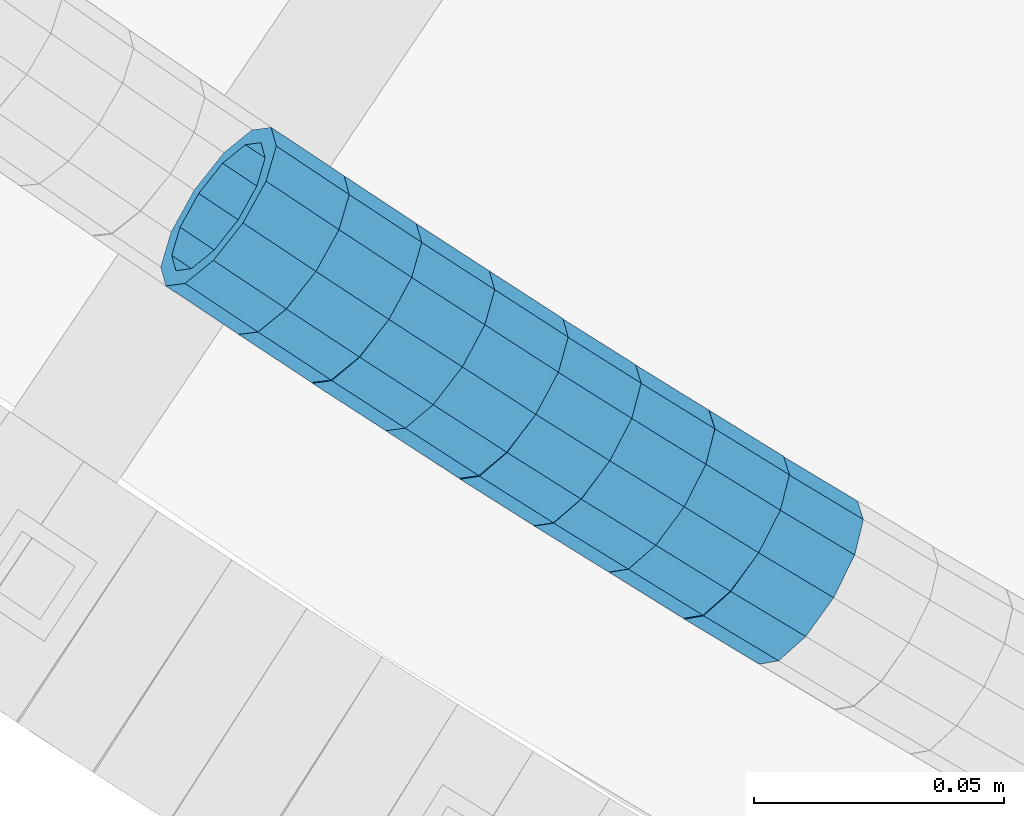
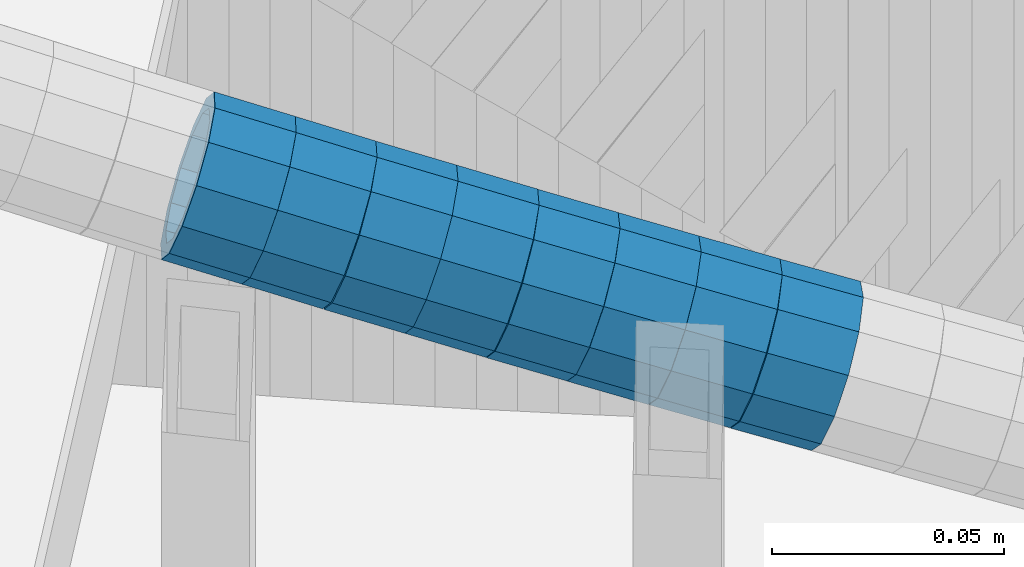
# One storey, part 645 of 975: 8 beams.
"""IFC2X3 building model written with IfcOpenShell, lengths in millimetres."""

from ifc_helpers import new_model, si_unit, frame, origin_with_axes, place, context, subcontext, project, spatial, faceted_brep, material, type_object, element, save


model = new_model("IFC2X3")

# Units and contexts
model_context = context("Model", 3, precision=1e-05, world=origin_with_axes())
body_context = subcontext(model_context, "Body", "Model", "MODEL_VIEW")
ifc_project = project(units=[si_unit("LENGTHUNIT", "METRE", prefix="MILLI"), si_unit("AREAUNIT", "SQUARE_METRE"), si_unit("VOLUMEUNIT", "CUBIC_METRE"), si_unit("MASSUNIT", "GRAM", prefix="KILO"), si_unit("TIMEUNIT", "SECOND"), si_unit("PLANEANGLEUNIT", "RADIAN"), si_unit("SOLIDANGLEUNIT", "STERADIAN"), si_unit("THERMODYNAMICTEMPERATUREUNIT", "DEGREE_CELSIUS"), si_unit("LUMINOUSINTENSITYUNIT", "LUMEN")], contexts=[model_context])

# Site, building, storey
site_placement = place(None, origin_with_axes())
site = spatial("IfcSite", under=ifc_project, at=site_placement, CompositionType="ELEMENT")
building_placement = place(site_placement, origin_with_axes())
building = spatial("IfcBuilding", under=site, at=building_placement, Name="Undefined", CompositionType="ELEMENT")
storey_placement = place(building_placement, origin_with_axes())
storey = spatial("IfcBuildingStorey", under=building, at=storey_placement, Name="Undefined", CompositionType="ELEMENT", Elevation=0.0)

# Beams
ifc_material = material()
beam_type = type_object("IfcBeamType", PredefinedType="NOTDEFINED")
beam_1_placement = place(storey_placement, frame((33190.7821561118, 1082.10456912707, 4744.82000192261), z_axis=(0.549406263499811, 0.835555358804655, -1.74246451933868e-10), x_axis=(0.793009938715005, -0.521431192812654, -0.315031344886818)))
element("IfcBeam", 1, at=beam_1_placement, inside=storey, type_object=beam_type, material=ifc_material, Name="WALL", context=body_context, shape_type="Brep", body=[
    faceted_brep([(-2.1246523829177e-07, -15.367000000002, 0.0), (-1.83998054126278e-07, -13.3082123799541, 7.68350000000009), (18.4143965418989, -13.3082123799722, 7.68350000004284), (18.4143965419134, -15.3670000000257, 5.82076609134674e-11), (-1.06232619145885e-07, -7.68349999999919, 13.3082123799559), (18.4143965418734, -7.68350000000646, 13.3082123799759), (-3.63797880709171e-12, 3.63797880709171e-12, 15.3670000000002), (18.414396541848, 3.63797880709171e-12, 15.3669999999984), (1.06225343188271e-07, 7.68350000000646, 13.3082123799559), (18.4143965418334, 7.6835000000101, 13.3082123799395), (1.8399441614747e-07, 13.308212379965, 7.68350000000009), (18.4143965418261, 13.3082123799686, 7.68349999997736), (2.12461600312963e-07, 15.3670000000093, 0.0), (18.4143965418334, 15.3670000000093, -1.81898940354586e-11), (1.8399441614747e-07, 13.308212379965, -7.68350000000009), (18.4143965418552, 13.3082123799577, -7.68349999999919), (1.06225343188271e-07, 7.68350000000646, -13.3082123799559), (18.4143965418734, 7.68349999999191, -13.3082123799322), (-3.63797880709171e-12, 3.63797880709171e-12, -15.3670000000002), (18.4143965418989, -2.00088834390044e-11, -15.3669999999584), (-1.06232619145885e-07, -7.68349999999919, -13.3082123799559), (18.4143965419134, -7.68350000002829, -13.3082123798958), (-1.83998054126278e-07, -13.3082123799541, -7.68350000000009), (18.4143965419207, -13.3082123799832, -7.6834999999337), (-2.63386027654633e-07, -19.0500000000029, 0.0), (-2.28097633225843e-07, -16.4977839420972, -9.52499999999964), (18.4143965419316, -16.4977839421263, -9.5249999999287), (18.4143965419207, -19.0500000000284, 6.54836185276508e-11), (-1.31691194837913e-07, -9.52500000000146, -16.4977839420935), (18.4143965419207, -9.52500000003056, -16.497783942028), (-3.63797880709171e-12, 3.63797880709171e-12, -19.0500000000002), (18.4143965419025, -2.18278728425503e-11, -19.049999999952), (1.31687556859106e-07, 9.52500000000509, -16.4977839420935), (18.4143965418771, 9.52499999999054, -16.4977839420717), (2.28097633225843e-07, 16.4977839421044, -9.52499999999964), (18.414396541848, 16.4977839420972, -9.52500000000146), (2.63382389675826e-07, 19.0500000000138, 0.0), (18.4143965418298, 19.050000000012, -2.18278728425503e-11), (2.28097633225843e-07, 16.4977839421044, 9.52499999999964), (18.4143965418225, 16.4977839421117, 9.52499999997235), (1.31687556859106e-07, 9.52500000000509, 16.4977839420935), (18.4143965418225, 9.52500000001601, 16.4977839420681), (-3.63797880709171e-12, 3.63797880709171e-12, 19.0500000000002), (18.4143965418443, 7.27595761418343e-12, 19.0499999999956), (-1.31691194837913e-07, -9.52500000000146, 16.4977839420935), (18.4143965418734, -9.52500000000691, 16.4977839421153), (-2.28097633225843e-07, -16.4977839420972, 9.52499999999964), (18.4143965418989, -16.4977839421117, 9.52500000004511)], [[[0, 1, 2, 3]], [[1, 4, 5, 2]], [[4, 6, 7, 5]], [[6, 8, 9, 7]], [[8, 10, 11, 9]], [[10, 12, 13, 11]], [[12, 14, 15, 13]], [[14, 16, 17, 15]], [[16, 18, 19, 17]], [[18, 20, 21, 19]], [[20, 22, 23, 21]], [[22, 0, 3, 23]], [[24, 25, 26, 27]], [[25, 28, 29, 26]], [[28, 30, 31, 29]], [[30, 32, 33, 31]], [[32, 34, 35, 33]], [[34, 36, 37, 35]], [[36, 38, 39, 37]], [[38, 40, 41, 39]], [[40, 42, 43, 41]], [[42, 44, 45, 43]], [[44, 46, 47, 45]], [[46, 24, 27, 47]], [[29, 31, 33, 35, 37, 39, 41, 43, 45, 47, 27, 26], [5, 7, 9, 11, 13, 15, 17, 19, 21, 23, 3, 2]], [[46, 44, 42, 40, 38, 36, 34, 32, 30, 28, 25, 24], [22, 20, 18, 16, 14, 12, 10, 8, 6, 4, 1, 0]]]),
])
beam_2_placement = place(storey_placement, frame((33176.2897568355, 1091.76742657612, 4750.48378012011), z_axis=(0.553382968473794, 0.832926941696048, -1.83026713784784e-10), x_axis=(0.792099090272937, -0.526257615181317, -0.30924416510657)))
element("IfcBeam", 2, at=beam_2_placement, inside=storey, type_object=beam_type, material=ifc_material, Name="WALL", context=body_context, shape_type="Brep", body=[
    faceted_brep([(-2.1246523829177e-07, -15.367000000002, 0.0), (-1.83998054126278e-07, -13.3082123799541, 7.68350000000009), (18.428781837134, -13.3082123799413, 7.68349999998827), (18.4287818371195, -15.3669999999802, -2.5465851649642e-11), (-1.06232619145885e-07, -7.68349999999919, 13.3082123799559), (18.4287818371522, -7.68349999999373, 13.3082123799577), (-3.63797880709171e-12, 3.63797880709171e-12, 15.3670000000002), (18.4287818371486, 5.45696821063757e-12, 15.367000000002), (1.06225343188271e-07, 7.68350000000646, 13.3082123799559), (18.4287818371558, 7.68350000000282, 13.3082123799577), (1.8399441614747e-07, 13.308212379965, 7.68350000000009), (18.4287818371413, 13.3082123799595, 7.68349999999191), (2.12461600312963e-07, 15.3670000000093, 0.0), (18.4287818371267, 15.3670000000075, -2.18278728425503e-11), (1.8399441614747e-07, 13.308212379965, -7.68350000000009), (18.4287818371122, 13.3082123799668, -7.68350000003193), (1.06225343188271e-07, 7.68350000000646, -13.3082123799559), (18.4287818370976, 7.68350000001737, -13.3082123800014), (-3.63797880709171e-12, 3.63797880709171e-12, -15.3670000000002), (18.428781837094, 2.00088834390044e-11, -15.3670000000529), (-1.06232619145885e-07, -7.68349999999919, -13.3082123799559), (18.4287818370976, -7.68349999997554, -13.308212380005), (-1.83998054126278e-07, -13.3082123799541, -7.68350000000009), (18.4287818371085, -13.308212379934, -7.6835000000392), (-2.63386027654633e-07, -19.0500000000029, 0.0), (-2.28097633225843e-07, -16.4977839420972, -9.52499999999964), (18.4287818371049, -16.4977839420699, -9.52500000004511), (18.4287818371231, -19.0499999999793, -2.5465851649642e-11), (-1.31691194837913e-07, -9.52500000000146, -16.4977839420935), (18.4287818370904, -9.52499999997599, -16.4977839421445), (-3.63797880709171e-12, 3.63797880709171e-12, -19.0500000000002), (18.4287818370831, 2.36468622460961e-11, -19.0500000000611), (1.31687556859106e-07, 9.52500000000509, -16.4977839420935), (18.4287818370904, 9.52500000001965, -16.4977839421481), (2.28097633225843e-07, 16.4977839421044, -9.52499999999964), (18.4287818371049, 16.4977839421063, -9.52500000004147), (2.63382389675826e-07, 19.0500000000138, 0.0), (18.4287818371304, 19.0500000000047, -2.18278728425503e-11), (2.28097633225843e-07, 16.4977839421044, 9.52499999999964), (18.4287818371486, 16.4977839420953, 9.52499999999782), (1.31687556859106e-07, 9.52500000000509, 16.4977839420935), (18.4287818371558, 9.52500000000146, 16.4977839421044), (-3.63797880709171e-12, 3.63797880709171e-12, 19.0500000000002), (18.4287818371631, 1.81898940354586e-12, 19.0500000000138), (-1.31691194837913e-07, -9.52500000000146, 16.4977839420935), (18.4287818371595, -9.52499999999236, 16.4977839421044), (-2.28097633225843e-07, -16.4977839420972, 9.52499999999964), (18.4287818371449, -16.4977839420808, 9.52499999999418)], [[[0, 1, 2, 3]], [[1, 4, 5, 2]], [[4, 6, 7, 5]], [[6, 8, 9, 7]], [[8, 10, 11, 9]], [[10, 12, 13, 11]], [[12, 14, 15, 13]], [[14, 16, 17, 15]], [[16, 18, 19, 17]], [[18, 20, 21, 19]], [[20, 22, 23, 21]], [[22, 0, 3, 23]], [[24, 25, 26, 27]], [[25, 28, 29, 26]], [[28, 30, 31, 29]], [[30, 32, 33, 31]], [[32, 34, 35, 33]], [[34, 36, 37, 35]], [[36, 38, 39, 37]], [[38, 40, 41, 39]], [[40, 42, 43, 41]], [[42, 44, 45, 43]], [[44, 46, 47, 45]], [[46, 24, 27, 47]], [[29, 31, 33, 35, 37, 39, 41, 43, 45, 47, 27, 26], [5, 7, 9, 11, 13, 15, 17, 19, 21, 23, 3, 2]], [[46, 44, 42, 40, 38, 36, 34, 32, 30, 28, 25, 24], [22, 20, 18, 16, 14, 12, 10, 8, 6, 4, 1, 0]]]),
])
beam_3_placement = place(storey_placement, frame((33205.4421759763, 1072.40923904148, 4738.98635280012), z_axis=(0.542777393936319, 0.839876598454617, -7.89877958595754e-11), x_axis=(0.798594669134802, -0.516098596087159, -0.309659157052298)))
element("IfcBeam", 3, at=beam_3_placement, inside=storey, type_object=beam_type, material=ifc_material, Name="WALL", context=body_context, shape_type="Brep", body=[
    faceted_brep([(-2.1246523829177e-07, -15.367000000002, 0.0), (-1.83998054126278e-07, -13.3082123799541, 7.68350000000009), (18.4143965418989, -13.3082123799722, 7.68350000004284), (18.4143965419134, -15.3670000000257, 5.82076609134674e-11), (-1.06232619145885e-07, -7.68349999999919, 13.3082123799559), (18.4143965418734, -7.68350000000646, 13.3082123799759), (-3.63797880709171e-12, 3.63797880709171e-12, 15.3670000000002), (18.414396541848, 3.63797880709171e-12, 15.3669999999984), (1.06225343188271e-07, 7.68350000000646, 13.3082123799559), (18.4143965418334, 7.6835000000101, 13.3082123799395), (1.8399441614747e-07, 13.308212379965, 7.68350000000009), (18.4143965418261, 13.3082123799686, 7.68349999997736), (2.12461600312963e-07, 15.3670000000093, 0.0), (18.4143965418334, 15.3670000000093, -1.81898940354586e-11), (1.8399441614747e-07, 13.308212379965, -7.68350000000009), (18.4143965418552, 13.3082123799577, -7.68349999999919), (1.06225343188271e-07, 7.68350000000646, -13.3082123799559), (18.4143965418734, 7.68349999999191, -13.3082123799322), (-3.63797880709171e-12, 3.63797880709171e-12, -15.3670000000002), (18.4143965418989, -2.00088834390044e-11, -15.3669999999584), (-1.06232619145885e-07, -7.68349999999919, -13.3082123799559), (18.4143965419134, -7.68350000002829, -13.3082123798958), (-1.83998054126278e-07, -13.3082123799541, -7.68350000000009), (18.4143965419207, -13.3082123799832, -7.6834999999337), (-2.63386027654633e-07, -19.0500000000029, 0.0), (-2.28097633225843e-07, -16.4977839420972, -9.52499999999964), (18.4143965419316, -16.4977839421263, -9.5249999999287), (18.4143965419207, -19.0500000000284, 6.54836185276508e-11), (-1.31691194837913e-07, -9.52500000000146, -16.4977839420935), (18.4143965419207, -9.52500000003056, -16.497783942028), (-3.63797880709171e-12, 3.63797880709171e-12, -19.0500000000002), (18.4143965419025, -2.18278728425503e-11, -19.049999999952), (1.31687556859106e-07, 9.52500000000509, -16.4977839420935), (18.4143965418771, 9.52499999999054, -16.4977839420717), (2.28097633225843e-07, 16.4977839421044, -9.52499999999964), (18.414396541848, 16.4977839420972, -9.52500000000146), (2.63382389675826e-07, 19.0500000000138, 0.0), (18.4143965418298, 19.050000000012, -2.18278728425503e-11), (2.28097633225843e-07, 16.4977839421044, 9.52499999999964), (18.4143965418225, 16.4977839421117, 9.52499999997235), (1.31687556859106e-07, 9.52500000000509, 16.4977839420935), (18.4143965418225, 9.52500000001601, 16.4977839420681), (-3.63797880709171e-12, 3.63797880709171e-12, 19.0500000000002), (18.4143965418443, 7.27595761418343e-12, 19.0499999999956), (-1.31691194837913e-07, -9.52500000000146, 16.4977839420935), (18.4143965418734, -9.52500000000691, 16.4977839421153), (-2.28097633225843e-07, -16.4977839420972, 9.52499999999964), (18.4143965418989, -16.4977839421117, 9.52500000004511)], [[[0, 1, 2, 3]], [[1, 4, 5, 2]], [[4, 6, 7, 5]], [[6, 8, 9, 7]], [[8, 10, 11, 9]], [[10, 12, 13, 11]], [[12, 14, 15, 13]], [[14, 16, 17, 15]], [[16, 18, 19, 17]], [[18, 20, 21, 19]], [[20, 22, 23, 21]], [[22, 0, 3, 23]], [[24, 25, 26, 27]], [[25, 28, 29, 26]], [[28, 30, 31, 29]], [[30, 32, 33, 31]], [[32, 34, 35, 33]], [[34, 36, 37, 35]], [[36, 38, 39, 37]], [[38, 40, 41, 39]], [[40, 42, 43, 41]], [[42, 44, 45, 43]], [[44, 46, 47, 45]], [[46, 24, 27, 47]], [[29, 31, 33, 35, 37, 39, 41, 43, 45, 47, 27, 26], [5, 7, 9, 11, 13, 15, 17, 19, 21, 23, 3, 2]], [[46, 44, 42, 40, 38, 36, 34, 32, 30, 28, 25, 24], [22, 20, 18, 16, 14, 12, 10, 8, 6, 4, 1, 0]]]),
])
beam_4_placement = place(storey_placement, frame((33220.1421759763, 1062.90923904149, 4733.28635280008), z_axis=(0.542777393936319, 0.839876598454617, -7.89877958595754e-11), x_axis=(0.798594669134802, -0.516098596087159, -0.309659157052298)))
element("IfcBeam", 4, at=beam_4_placement, inside=storey, type_object=beam_type, material=ifc_material, Name="WALL", context=body_context, shape_type="Brep", body=[
    faceted_brep([(-2.1246523829177e-07, -15.367000000002, 0.0), (-1.83998054126278e-07, -13.3082123799541, 7.68350000000009), (18.4143965418989, -13.3082123799722, 7.68350000004284), (18.4143965419134, -15.3670000000257, 5.82076609134674e-11), (-1.06232619145885e-07, -7.68349999999919, 13.3082123799559), (18.4143965418734, -7.68350000000646, 13.3082123799759), (-3.63797880709171e-12, 3.63797880709171e-12, 15.3670000000002), (18.414396541848, 3.63797880709171e-12, 15.3669999999984), (1.06225343188271e-07, 7.68350000000646, 13.3082123799559), (18.4143965418334, 7.6835000000101, 13.3082123799395), (1.8399441614747e-07, 13.308212379965, 7.68350000000009), (18.4143965418261, 13.3082123799686, 7.68349999997736), (2.12461600312963e-07, 15.3670000000093, 0.0), (18.4143965418334, 15.3670000000093, -1.81898940354586e-11), (1.8399441614747e-07, 13.308212379965, -7.68350000000009), (18.4143965418552, 13.3082123799577, -7.68349999999919), (1.06225343188271e-07, 7.68350000000646, -13.3082123799559), (18.4143965418734, 7.68349999999191, -13.3082123799322), (-3.63797880709171e-12, 3.63797880709171e-12, -15.3670000000002), (18.4143965418989, -2.00088834390044e-11, -15.3669999999584), (-1.06232619145885e-07, -7.68349999999919, -13.3082123799559), (18.4143965419134, -7.68350000002829, -13.3082123798958), (-1.83998054126278e-07, -13.3082123799541, -7.68350000000009), (18.4143965419207, -13.3082123799832, -7.6834999999337), (-2.63386027654633e-07, -19.0500000000029, 0.0), (-2.28097633225843e-07, -16.4977839420972, -9.52499999999964), (18.4143965419316, -16.4977839421263, -9.5249999999287), (18.4143965419207, -19.0500000000284, 6.54836185276508e-11), (-1.31691194837913e-07, -9.52500000000146, -16.4977839420935), (18.4143965419207, -9.52500000003056, -16.497783942028), (-3.63797880709171e-12, 3.63797880709171e-12, -19.0500000000002), (18.4143965419025, -2.18278728425503e-11, -19.049999999952), (1.31687556859106e-07, 9.52500000000509, -16.4977839420935), (18.4143965418771, 9.52499999999054, -16.4977839420717), (2.28097633225843e-07, 16.4977839421044, -9.52499999999964), (18.414396541848, 16.4977839420972, -9.52500000000146), (2.63382389675826e-07, 19.0500000000138, 0.0), (18.4143965418298, 19.050000000012, -2.18278728425503e-11), (2.28097633225843e-07, 16.4977839421044, 9.52499999999964), (18.4143965418225, 16.4977839421117, 9.52499999997235), (1.31687556859106e-07, 9.52500000000509, 16.4977839420935), (18.4143965418225, 9.52500000001601, 16.4977839420681), (-3.63797880709171e-12, 3.63797880709171e-12, 19.0500000000002), (18.4143965418443, 7.27595761418343e-12, 19.0499999999956), (-1.31691194837913e-07, -9.52500000000146, 16.4977839420935), (18.4143965418734, -9.52500000000691, 16.4977839421153), (-2.28097633225843e-07, -16.4977839420972, 9.52499999999964), (18.4143965418989, -16.4977839421117, 9.52500000004511)], [[[0, 1, 2, 3]], [[1, 4, 5, 2]], [[4, 6, 7, 5]], [[6, 8, 9, 7]], [[8, 10, 11, 9]], [[10, 12, 13, 11]], [[12, 14, 15, 13]], [[14, 16, 17, 15]], [[16, 18, 19, 17]], [[18, 20, 21, 19]], [[20, 22, 23, 21]], [[22, 0, 3, 23]], [[24, 25, 26, 27]], [[25, 28, 29, 26]], [[28, 30, 31, 29]], [[30, 32, 33, 31]], [[32, 34, 35, 33]], [[34, 36, 37, 35]], [[36, 38, 39, 37]], [[38, 40, 41, 39]], [[40, 42, 43, 41]], [[42, 44, 45, 43]], [[44, 46, 47, 45]], [[46, 24, 27, 47]], [[29, 31, 33, 35, 37, 39, 41, 43, 45, 47, 27, 26], [5, 7, 9, 11, 13, 15, 17, 19, 21, 23, 3, 2]], [[46, 44, 42, 40, 38, 36, 34, 32, 30, 28, 25, 24], [22, 20, 18, 16, 14, 12, 10, 8, 6, 4, 1, 0]]]),
])
beam_5_placement = place(storey_placement, frame((33234.7958836882, 1053.34974214554, 4727.58865473014), z_axis=(0.532054374643281, 0.846710187976351, 9.43909981288016e-11), x_axis=(0.804990058091852, -0.50583834705768, -0.310029955035366)))
element("IfcBeam", 5, at=beam_5_placement, inside=storey, type_object=beam_type, material=ifc_material, Name="WALL", context=body_context, shape_type="Brep", body=[
    faceted_brep([(-2.1246523829177e-07, -15.367000000002, 0.0), (-1.83998054126278e-07, -13.3082123799541, 7.68350000000009), (18.3929334256754, -13.3082123799595, 7.68350000001374), (18.39293342569, -15.3670000000111, 3.27418092638254e-11), (-1.06232619145885e-07, -7.68349999999919, 13.3082123799559), (18.3929334256572, -7.68349999999373, 13.3082123799504), (-3.63797880709171e-12, 3.63797880709171e-12, 15.3670000000002), (18.3929334256391, 1.2732925824821e-11, 15.3669999999802), (1.06225343188271e-07, 7.68350000000646, 13.3082123799559), (18.3929334256318, 7.68350000001556, 13.3082123799286), (1.8399441614747e-07, 13.308212379965, 7.68350000000009), (18.3929334256391, 13.3082123799704, 7.68349999997736), (2.12461600312963e-07, 15.3670000000093, 0.0), (18.3929334256536, 15.3670000000111, -1.09139364212751e-11), (1.8399441614747e-07, 13.308212379965, -7.68350000000009), (18.3929334256682, 13.3082123799595, -7.68349999999191), (1.06225343188271e-07, 7.68350000000646, -13.3082123799559), (18.3929334256864, 7.68349999999373, -13.3082123799286), (-3.63797880709171e-12, 3.63797880709171e-12, -15.3670000000002), (18.3929334257045, -1.2732925824821e-11, -15.3669999999584), (-1.06232619145885e-07, -7.68349999999919, -13.3082123799559), (18.3929334257118, -7.68350000001919, -13.3082123799068), (-1.83998054126278e-07, -13.3082123799541, -7.68350000000009), (18.3929334257082, -13.3082123799704, -7.68349999995553), (-2.63386027654633e-07, -19.0500000000029, 0.0), (-2.28097633225843e-07, -16.4977839420972, -9.52499999999964), (18.3929334257155, -16.4977839421135, -9.52499999994689), (18.3929334257009, -19.0500000000156, 3.63797880709171e-11), (-1.31691194837913e-07, -9.52500000000146, -16.4977839420935), (18.3929334257191, -9.52500000002146, -16.4977839420353), (-3.63797880709171e-12, 3.63797880709171e-12, -19.0500000000002), (18.3929334257155, -1.81898940354586e-11, -19.0499999999483), (1.31687556859106e-07, 9.52500000000509, -16.4977839420935), (18.3929334256936, 9.52499999999236, -16.4977839420608), (2.28097633225843e-07, 16.4977839421044, -9.52499999999964), (18.3929334256682, 16.4977839420953, -9.52499999999418), (2.63382389675826e-07, 19.0500000000138, 0.0), (18.3929334256391, 19.050000000012, -1.81898940354586e-11), (2.28097633225843e-07, 16.4977839421044, 9.52499999999964), (18.3929334256281, 16.4977839421117, 9.52499999996508), (1.31687556859106e-07, 9.52500000000509, 16.4977839420935), (18.3929334256245, 9.52500000001965, 16.4977839420571), (-3.63797880709171e-12, 3.63797880709171e-12, 19.0500000000002), (18.3929334256318, 1.63709046319127e-11, 19.0499999999738), (-1.31691194837913e-07, -9.52500000000146, 16.4977839420935), (18.39293342565, -9.52499999999236, 16.4977839420826), (-2.28097633225843e-07, -16.4977839420972, 9.52499999999964), (18.3929334256754, -16.497783942099, 9.52500000001601)], [[[0, 1, 2, 3]], [[1, 4, 5, 2]], [[4, 6, 7, 5]], [[6, 8, 9, 7]], [[8, 10, 11, 9]], [[10, 12, 13, 11]], [[12, 14, 15, 13]], [[14, 16, 17, 15]], [[16, 18, 19, 17]], [[18, 20, 21, 19]], [[20, 22, 23, 21]], [[22, 0, 3, 23]], [[24, 25, 26, 27]], [[25, 28, 29, 26]], [[28, 30, 31, 29]], [[30, 32, 33, 31]], [[32, 34, 35, 33]], [[34, 36, 37, 35]], [[36, 38, 39, 37]], [[38, 40, 41, 39]], [[40, 42, 43, 41]], [[42, 44, 45, 43]], [[44, 46, 47, 45]], [[46, 24, 27, 47]], [[29, 31, 33, 35, 37, 39, 41, 43, 45, 47, 27, 26], [5, 7, 9, 11, 13, 15, 17, 19, 21, 23, 3, 2]], [[46, 44, 42, 40, 38, 36, 34, 32, 30, 28, 25, 24], [22, 20, 18, 16, 14, 12, 10, 8, 6, 4, 1, 0]]]),
])
beam_6_placement = place(storey_placement, frame((33249.5002178929, 1044.05415940907, 4721.91610945647), z_axis=(0.52537129833088, 0.850873080365178, -2.03714080271311e-10), x_axis=(0.80772155900317, -0.49872740600192, -0.314415104001199)))
element("IfcBeam", 6, at=beam_6_placement, inside=storey, type_object=beam_type, material=ifc_material, Name="WALL", context=body_context, shape_type="Brep", body=[
    faceted_brep([(-2.1246523829177e-07, -15.367000000002, 0.0), (-1.83998054126278e-07, -13.3082123799541, 7.68350000000009), (18.4537259110693, -13.3082123799595, 7.68349999998827), (18.453725911073, -15.3670000000038, 0.0), (-1.06232619145885e-07, -7.68349999999919, 13.3082123799559), (18.4537259110621, -7.683500000001, 13.3082123799431), (-3.63797880709171e-12, 3.63797880709171e-12, 15.3670000000002), (18.453725911073, -1.81898940354586e-12, 15.3669999999911), (1.06225343188271e-07, 7.68350000000646, 13.3082123799559), (18.4537259110839, 7.68349999999737, 13.3082123799504), (1.8399441614747e-07, 13.308212379965, 7.68350000000009), (18.4537259110948, 13.3082123799522, 7.68350000000646), (2.12461600312963e-07, 15.3670000000093, 0.0), (18.4537259111057, 15.3669999999947, 1.09139364212751e-11), (1.8399441614747e-07, 13.308212379965, -7.68350000000009), (18.4537259111203, 13.3082123799486, -7.68349999997372), (1.06225343188271e-07, 7.68350000000646, -13.3082123799559), (18.4537259111166, 7.68349999999373, -13.3082123799322), (-3.63797880709171e-12, 3.63797880709171e-12, -15.3670000000002), (18.4537259111094, -5.45696821063757e-12, -15.3669999999765), (-1.06232619145885e-07, -7.68349999999919, -13.3082123799559), (18.4537259111057, -7.68350000000646, -13.3082123799395), (-1.83998054126278e-07, -13.3082123799541, -7.68350000000009), (18.4537259110912, -13.3082123799595, -7.68349999999555), (-2.63386027654633e-07, -19.0500000000029, 0.0), (-2.28097633225843e-07, -16.4977839420972, -9.52499999999964), (18.4537259110839, -16.497783942099, -9.52499999999418), (18.453725911073, -19.0500000000029, -7.27595761418343e-12), (-1.31691194837913e-07, -9.52500000000146, -16.4977839420935), (18.4537259111057, -9.52500000000509, -16.497783942079), (-3.63797880709171e-12, 3.63797880709171e-12, -19.0500000000002), (18.4537259111166, -7.27595761418343e-12, -19.0499999999702), (1.31687556859106e-07, 9.52500000000509, -16.4977839420935), (18.4537259111275, 9.52499999999236, -16.4977839420608), (2.28097633225843e-07, 16.4977839421044, -9.52499999999964), (18.4537259111239, 16.4977839420881, -9.52499999997235), (2.63382389675826e-07, 19.0500000000138, 0.0), (18.4537259111057, 19.0499999999938, 1.81898940354586e-11), (2.28097633225843e-07, 16.4977839421044, 9.52499999999964), (18.4537259110948, 16.4977839420917, 9.52500000000509), (1.31687556859106e-07, 9.52500000000509, 16.4977839420935), (18.4537259110803, 9.52499999999782, 16.4977839420862), (-3.63797880709171e-12, 3.63797880709171e-12, 19.0500000000002), (18.4537259110621, -1.81898940354586e-12, 19.0499999999811), (-1.31691194837913e-07, -9.52500000000146, 16.4977839420935), (18.4537259110584, -9.52500000000146, 16.4977839420753), (-2.28097633225843e-07, -16.4977839420972, 9.52499999999964), (18.4537259110621, -16.4977839420953, 9.52499999998327)], [[[0, 1, 2, 3]], [[1, 4, 5, 2]], [[4, 6, 7, 5]], [[6, 8, 9, 7]], [[8, 10, 11, 9]], [[10, 12, 13, 11]], [[12, 14, 15, 13]], [[14, 16, 17, 15]], [[16, 18, 19, 17]], [[18, 20, 21, 19]], [[20, 22, 23, 21]], [[22, 0, 3, 23]], [[24, 25, 26, 27]], [[25, 28, 29, 26]], [[28, 30, 31, 29]], [[30, 32, 33, 31]], [[32, 34, 35, 33]], [[34, 36, 37, 35]], [[36, 38, 39, 37]], [[38, 40, 41, 39]], [[40, 42, 43, 41]], [[42, 44, 45, 43]], [[44, 46, 47, 45]], [[46, 24, 27, 47]], [[29, 31, 33, 35, 37, 39, 41, 43, 45, 47, 27, 26], [5, 7, 9, 11, 13, 15, 17, 19, 21, 23, 3, 2]], [[46, 44, 42, 40, 38, 36, 34, 32, 30, 28, 25, 24], [22, 20, 18, 16, 14, 12, 10, 8, 6, 4, 1, 0]]]),
])
beam_7_placement = place(storey_placement, frame((33264.4796021932, 1034.80514359947, 4716.08547480087), z_axis=(0.52537129833088, 0.850873080365178, -2.03714080271311e-10), x_axis=(0.809089863969454, -0.499572264981154, -0.309517598988313)))
element("IfcBeam", 7, at=beam_7_placement, inside=storey, type_object=beam_type, material=ifc_material, Name="WALL", context=body_context, shape_type="Brep", body=[
    faceted_brep([(-2.1246523829177e-07, -15.367000000002, 0.0), (-1.83998054126278e-07, -13.3082123799541, 7.68350000000009), (18.4154826165905, -13.3082123799504, 7.68350000000646), (18.4154826165941, -15.3669999999984, 7.27595761418343e-12), (-1.06232619145885e-07, -7.68349999999919, 13.3082123799559), (18.4154826165905, -7.68349999999373, 13.308212379965), (-3.63797880709171e-12, 3.63797880709171e-12, 15.3670000000002), (18.4154826165941, 3.63797880709171e-12, 15.3670000000093), (1.06225343188271e-07, 7.68350000000646, 13.3082123799559), (18.4154826166014, 7.68349999999919, 13.3082123799722), (1.8399441614747e-07, 13.308212379965, 7.68350000000009), (18.4154826166086, 13.3082123799468, 7.68350000002465), (2.12461600312963e-07, 15.3670000000093, 0.0), (18.4154826166196, 15.366999999982, 2.91038304567337e-11), (1.8399441614747e-07, 13.308212379965, -7.68350000000009), (18.4154826166232, 13.3082123799377, -7.68349999997008), (1.06225343188271e-07, 7.68350000000646, -13.3082123799559), (18.4154826166305, 7.68349999997918, -13.308212379925), (-3.63797880709171e-12, 3.63797880709171e-12, -15.3670000000002), (18.4154826166196, -1.63709046319127e-11, -15.3669999999729), (-1.06232619145885e-07, -7.68349999999919, -13.3082123799559), (18.4154826166123, -7.68350000001374, -13.3082123799359), (-1.83998054126278e-07, -13.3082123799541, -7.68350000000009), (18.415482616605, -13.3082123799613, -7.68349999998463), (-2.63386027654633e-07, -19.0500000000029, 0.0), (-2.28097633225843e-07, -16.4977839420972, -9.52499999999964), (18.415482616605, -16.497783942099, -9.5249999999869), (18.4154826165941, -19.0499999999975, 3.63797880709171e-12), (-1.31691194837913e-07, -9.52500000000146, -16.4977839420935), (18.4154826166196, -9.52500000001601, -16.4977839420681), (-3.63797880709171e-12, 3.63797880709171e-12, -19.0500000000002), (18.4154826166268, -2.18278728425503e-11, -19.0499999999702), (1.31687556859106e-07, 9.52500000000509, -16.4977839420935), (18.4154826166305, 9.52499999997781, -16.4977839420608), (2.28097633225843e-07, 16.4977839421044, -9.52499999999964), (18.4154826166268, 16.4977839420717, -9.52499999996508), (2.63382389675826e-07, 19.0500000000138, 0.0), (18.4154826166196, 19.0499999999847, 2.5465851649642e-11), (2.28097633225843e-07, 16.4977839421044, 9.52499999999964), (18.4154826166086, 16.4977839420844, 9.52500000001965), (1.31687556859106e-07, 9.52500000000509, 16.4977839420935), (18.4154826165941, 9.52500000000146, 16.4977839421081), (-3.63797880709171e-12, 3.63797880709171e-12, 19.0500000000002), (18.4154826165868, 7.27595761418343e-12, 19.0500000000065), (-1.31691194837913e-07, -9.52500000000146, 16.4977839420935), (18.4154826165868, -9.52499999999236, 16.4977839421008), (-2.28097633225843e-07, -16.4977839420972, 9.52499999999964), (18.4154826165868, -16.4977839420862, 9.52500000000146)], [[[0, 1, 2, 3]], [[1, 4, 5, 2]], [[4, 6, 7, 5]], [[6, 8, 9, 7]], [[8, 10, 11, 9]], [[10, 12, 13, 11]], [[12, 14, 15, 13]], [[14, 16, 17, 15]], [[16, 18, 19, 17]], [[18, 20, 21, 19]], [[20, 22, 23, 21]], [[22, 0, 3, 23]], [[24, 25, 26, 27]], [[25, 28, 29, 26]], [[28, 30, 31, 29]], [[30, 32, 33, 31]], [[32, 34, 35, 33]], [[34, 36, 37, 35]], [[36, 38, 39, 37]], [[38, 40, 41, 39]], [[40, 42, 43, 41]], [[42, 44, 45, 43]], [[44, 46, 47, 45]], [[46, 24, 27, 47]], [[29, 31, 33, 35, 37, 39, 41, 43, 45, 47, 27, 26], [5, 7, 9, 11, 13, 15, 17, 19, 21, 23, 3, 2]], [[46, 44, 42, 40, 38, 36, 34, 32, 30, 28, 25, 24], [22, 20, 18, 16, 14, 12, 10, 8, 6, 4, 1, 0]]]),
])
beam_8_placement = place(storey_placement, frame((33279.3357173171, 1025.54392935501, 4710.38731766493), z_axis=(0.514495754965712, 0.857492925989633, 7.84348230808974e-12), x_axis=(0.815301680931507, -0.489181007958907, -0.309814638973963)))
element("IfcBeam", 8, at=beam_8_placement, inside=storey, type_object=beam_type, material=ifc_material, Name="WALL", context=body_context, shape_type="Brep", body=[
    faceted_brep([(-2.1246523829177e-07, -15.367000000002, 0.0), (-1.83998054126278e-07, -13.3082123799541, 7.68350000000009), (18.4002717371586, -13.3082123799486, 7.6835000000101), (18.4002717371732, -15.3670000000002, 2.5465851649642e-11), (-1.06232619145885e-07, -7.68349999999919, 13.3082123799559), (18.4002717371368, -7.68349999998645, 13.3082123799431), (-3.63797880709171e-12, 3.63797880709171e-12, 15.3670000000002), (18.400271737115, 2.00088834390044e-11, 15.3669999999656), (1.06225343188271e-07, 7.68350000000646, 13.3082123799559), (18.4002717371004, 7.68350000002283, 13.3082123799068), (1.8399441614747e-07, 13.308212379965, 7.68350000000009), (18.4002717370895, 13.3082123799741, 7.68349999994462), (2.12461600312963e-07, 15.3670000000093, 0.0), (18.4002717370931, 15.3670000000147, -5.45696821063757e-11), (1.8399441614747e-07, 13.308212379965, -7.68350000000009), (18.4002717371004, 13.3082123799632, -7.6835000000392), (1.06225343188271e-07, 7.68350000000646, -13.3082123799559), (18.4002717371259, 7.68349999999919, -13.3082123799759), (-3.63797880709171e-12, 3.63797880709171e-12, -15.3670000000002), (18.4002717371513, -5.45696821063757e-12, -15.3669999999984), (-1.06232619145885e-07, -7.68349999999919, -13.3082123799559), (18.4002717371659, -7.68350000000646, -13.3082123799395), (-1.83998054126278e-07, -13.3082123799541, -7.68350000000009), (18.4002717371732, -13.3082123799613, -7.68349999997736), (-2.63386027654633e-07, -19.0500000000029, 0.0), (-2.28097633225843e-07, -16.4977839420972, -9.52499999999964), (18.4002717371877, -16.4977839421026, -9.52499999996508), (18.4002717371841, -19.0500000000029, 3.63797880709171e-11), (-1.31691194837913e-07, -9.52500000000146, -16.4977839420935), (18.4002717371768, -9.52500000001055, -16.4977839420681), (-3.63797880709171e-12, 3.63797880709171e-12, -19.0500000000002), (18.400271737155, -9.09494701772928e-12, -19.0499999999956), (1.31687556859106e-07, 9.52500000000509, -16.4977839420935), (18.4002717371295, 9.52499999999782, -16.4977839421153), (2.28097633225843e-07, 16.4977839421044, -9.52499999999964), (18.4002717370968, 16.4977839421026, -9.52500000005239), (2.63382389675826e-07, 19.0500000000138, 0.0), (18.4002717370822, 19.0500000000156, -6.54836185276508e-11), (2.28097633225843e-07, 16.4977839421044, 9.52499999999964), (18.4002717370786, 16.4977839421172, 9.52499999993233), (1.31687556859106e-07, 9.52500000000509, 16.4977839420935), (18.4002717370859, 9.5250000000251, 16.497783942039), (-3.63797880709171e-12, 3.63797880709171e-12, 19.0500000000002), (18.4002717371113, 2.36468622460961e-11, 19.0499999999629), (-1.31691194837913e-07, -9.52500000000146, 16.4977839420935), (18.4002717371368, -9.52499999998327, 16.4977839420826), (-2.28097633225843e-07, -16.4977839420972, 9.52499999999964), (18.4002717371623, -16.4977839420844, 9.52500000001601)], [[[0, 1, 2, 3]], [[1, 4, 5, 2]], [[4, 6, 7, 5]], [[6, 8, 9, 7]], [[8, 10, 11, 9]], [[10, 12, 13, 11]], [[12, 14, 15, 13]], [[14, 16, 17, 15]], [[16, 18, 19, 17]], [[18, 20, 21, 19]], [[20, 22, 23, 21]], [[22, 0, 3, 23]], [[24, 25, 26, 27]], [[25, 28, 29, 26]], [[28, 30, 31, 29]], [[30, 32, 33, 31]], [[32, 34, 35, 33]], [[34, 36, 37, 35]], [[36, 38, 39, 37]], [[38, 40, 41, 39]], [[40, 42, 43, 41]], [[42, 44, 45, 43]], [[44, 46, 47, 45]], [[46, 24, 27, 47]], [[29, 31, 33, 35, 37, 39, 41, 43, 45, 47, 27, 26], [5, 7, 9, 11, 13, 15, 17, 19, 21, 23, 3, 2]], [[46, 44, 42, 40, 38, 36, 34, 32, 30, 28, 25, 24], [22, 20, 18, 16, 14, 12, 10, 8, 6, 4, 1, 0]]]),
])

save(model, "model.ifc")
